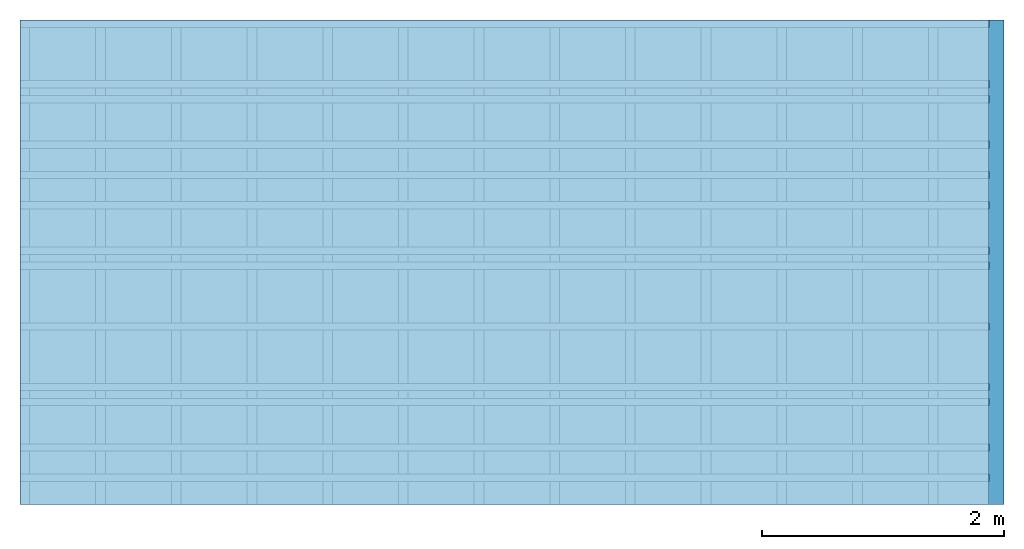
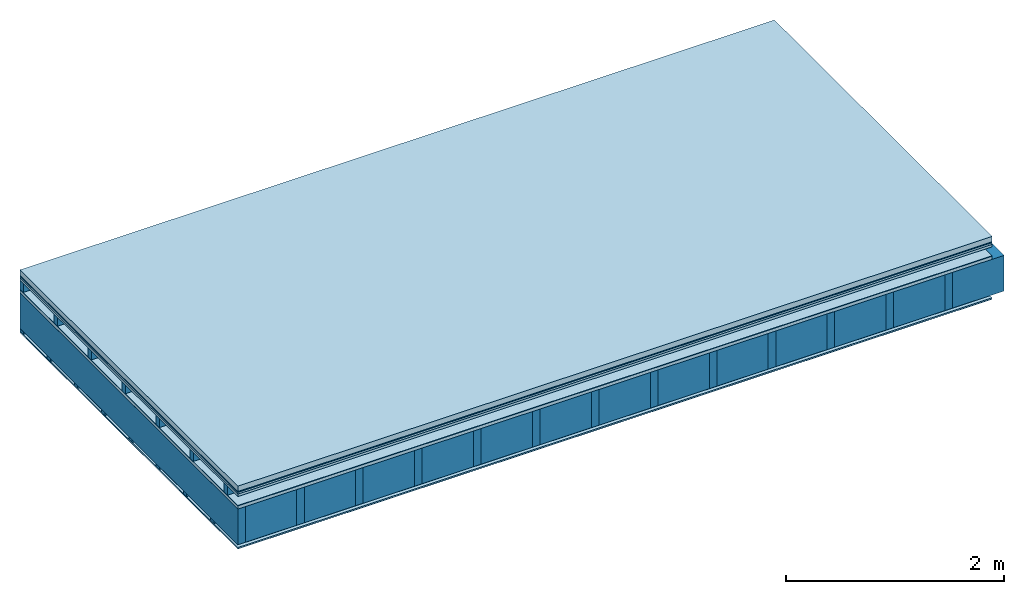
# One storey: 9 plates, 4 members, 1 element without a shape of its own.
"""IFC4 building model written with IfcOpenShell, lengths in metres."""

from ifc_helpers import new_model, si_unit, derived_unit, direction, frame, frame_2d, origin, origin_with_axes, place, context, project, spatial, rectangle, extrude, material, layer, layer_set, type_object, element, aggregate, save


model = new_model("IFC4")

# Units and contexts
plan_context = context("Plan", 3, precision=1e-05, world=origin(), true_north=direction((0.0, 1.0)))
model_context = context("Model", 3, precision=1e-05, world=origin(), true_north=direction((0.0, 1.0)))
ifc_project = project(units=[si_unit("LENGTHUNIT", "METRE"), derived_unit("SOUNDPRESSUREUNIT", [(si_unit("PRESSUREUNIT", "PASCAL", prefix="MICRO"), 0)]), si_unit("ENERGYUNIT", "JOULE", prefix="MEGA"), si_unit("MASSUNIT", "GRAM", prefix="KILO"), derived_unit("THERMALTRANSMITTANCEUNIT", [(si_unit("POWERUNIT", "WATT"), 1), (si_unit("AREAUNIT", "SQUARE_METRE"), -1), (si_unit("THERMODYNAMICTEMPERATUREUNIT", "KELVIN"), -1)]), derived_unit("AREADENSITYUNIT", [(si_unit("MASSUNIT", "GRAM", prefix="KILO"), 1), (si_unit("AREAUNIT", "SQUARE_METRE"), -1)]), derived_unit("USERDEFINED", [(si_unit("ENERGYUNIT", "JOULE", prefix="MEGA"), 1), (si_unit("AREAUNIT", "SQUARE_METRE"), -1)])], contexts=[plan_context, model_context])

# Site, building, storey
site = spatial("IfcSite", under=ifc_project)
building_placement = place(None, origin())
building = spatial("IfcBuilding", under=site, at=building_placement)
storey_placement = place(building_placement, origin())
storey = spatial("IfcBuildingStorey", under=building, at=storey_placement)

# Slab, members, plates
ifc_material_1 = material(Name="clay", Category="02.004")
ifc_layer_1 = layer(ifc_material_1, 0.06, Name="Use and protection layer 2")
ifc_material_2 = material(Name="Protective layer", Category="09.007")
ifc_layer_2 = layer(ifc_material_2, 0.01, Name="Use and protection layer 1")
ifc_material_3 = material(Name="Bituminous", Category="09.003")
ifc_layer_3 = layer(ifc_material_3, 0.02, Name="Seal")
ifc_material_4 = material(Category="07.009")
ifc_layer_4 = layer(ifc_material_4, 0.027, Name="Covering 1st layer")
ifc_layer_5 = layer(None, 0.1, Name="Battens / profiles")
ifc_material_5 = material(Name="Roofing underlay", Category="09.008")
ifc_layer_6 = layer(ifc_material_5, 0.005, Name="Under the roof")
ifc_material_6 = material(Category="10.009")
ifc_layer_7 = layer(ifc_material_6, 0.035, Name="above 2nd layer")
ifc_material_7 = material(Name="no composite action")
ifc_layer_8 = layer(ifc_material_7, 0.0, Name="Bond")
ifc_layer_9 = layer(None, 0.4, Name="Support")
ifc_material_8 = material(Name="of the art")
ifc_layer_10 = layer(ifc_material_8, 0.0, Name="Bond")
ifc_material_9 = material(Name="Vapor barrier polyethylene (PE)", Category="09.002")
ifc_layer_11 = layer(ifc_material_9, 0.001, Name="Vapor barrier")
ifc_layer_12 = layer(None, 0.03, Name="Battens / profiles")
ifc_material_10 = material(Name="DFH2IR Knauf Diamant hard- plasterboard", Category="03.007")
ifc_layer_13 = layer(ifc_material_10, 0.015, Name="Covering below 1st layer")
ifc_material_11 = material(Category="04.001")
ifc_layer_14 = layer(ifc_material_11, 0.003, Name="Surface below")
ifc_layer_set = layer_set([ifc_layer_1, ifc_layer_2, ifc_layer_3, ifc_layer_4, ifc_layer_5, ifc_layer_6, ifc_layer_7, ifc_layer_8, ifc_layer_9, ifc_layer_10, ifc_layer_11, ifc_layer_12, ifc_layer_13, ifc_layer_14])
slab_type = type_object("IfcSlabType", Name="F0120", PredefinedType="NOTDEFINED", material=ifc_layer_set)
slab_placement = place(None, frame((0.0, 0.0, 0.0), z_axis=(0.0, 0.0, -1.0), x_axis=(1.0, 0.0, 0.0)))
slab = element("IfcSlab", 1, at=slab_placement, inside=storey, type_object=slab_type, material=ifc_layer_set, Name="Slab #1")
ifc_material_12 = material()
member_1_placement = place(slab_placement, origin())
member_1 = element("IfcMember", 2, at=member_1_placement, material=ifc_material_12, Name="Battens / profiles", context=plan_context, shape_type="SweptSolid", body=[
    extrude(rectangle(XDim=0.06, YDim=0.1, at=frame_2d((0.03, 0.05), x_axis=(1.0, 0.0))), frame((0.0, 0.0, 0.117), z_axis=(1.0, 0.0, 0.0), x_axis=(0.0, 1.0, 0.0)), (0.0, 0.0, 1.0), 8.0),
    extrude(rectangle(XDim=0.06, YDim=0.1, at=frame_2d((0.03, 0.05), x_axis=(1.0, 0.0))), frame((0.0, 0.625, 0.117), z_axis=(1.0, 0.0, 0.0), x_axis=(0.0, 1.0, 0.0)), (0.0, 0.0, 1.0), 8.0),
    extrude(rectangle(XDim=0.06, YDim=0.1, at=frame_2d((0.03, 0.05), x_axis=(1.0, 0.0))), frame((0.0, 1.25, 0.117), z_axis=(1.0, 0.0, 0.0), x_axis=(0.0, 1.0, 0.0)), (0.0, 0.0, 1.0), 8.0),
    extrude(rectangle(XDim=0.06, YDim=0.1, at=frame_2d((0.03, 0.05), x_axis=(1.0, 0.0))), frame((0.0, 1.875, 0.117), z_axis=(1.0, 0.0, 0.0), x_axis=(0.0, 1.0, 0.0)), (0.0, 0.0, 1.0), 8.0),
    extrude(rectangle(XDim=0.06, YDim=0.1, at=frame_2d((0.03, 0.05), x_axis=(1.0, 0.0))), frame((0.0, 2.5, 0.117), z_axis=(1.0, 0.0, 0.0), x_axis=(0.0, 1.0, 0.0)), (0.0, 0.0, 1.0), 8.0),
    extrude(rectangle(XDim=0.06, YDim=0.1, at=frame_2d((0.03, 0.05), x_axis=(1.0, 0.0))), frame((0.0, 3.125, 0.117), z_axis=(1.0, 0.0, 0.0), x_axis=(0.0, 1.0, 0.0)), (0.0, 0.0, 1.0), 8.0),
    extrude(rectangle(XDim=0.06, YDim=0.1, at=frame_2d((0.03, 0.05), x_axis=(1.0, 0.0))), frame((0.0, 3.75, 0.117), z_axis=(1.0, 0.0, 0.0), x_axis=(0.0, 1.0, 0.0)), (0.0, 0.0, 1.0), 8.0),
])
ifc_material_13 = material()
member_2_placement = place(slab_placement, origin())
member_2 = element("IfcMember", 3, at=member_2_placement, material=ifc_material_13, Name="Support", context=plan_context, shape_type="SweptSolid", body=[
    extrude(rectangle(XDim=0.08, YDim=0.4, at=frame_2d((0.04, 0.2), x_axis=(1.0, 0.0))), frame((0.0, 4.0, 0.257), z_axis=(0.0, -1.0, 0.0), x_axis=(1.0, 0.0, 0.0)), (0.0, 0.0, 1.0), 4.0),
    extrude(rectangle(XDim=0.08, YDim=0.4, at=frame_2d((0.04, 0.2), x_axis=(1.0, 0.0))), frame((0.625, 4.0, 0.257), z_axis=(0.0, -1.0, 0.0), x_axis=(1.0, 0.0, 0.0)), (0.0, 0.0, 1.0), 4.0),
    extrude(rectangle(XDim=0.08, YDim=0.4, at=frame_2d((0.04, 0.2), x_axis=(1.0, 0.0))), frame((1.25, 4.0, 0.257), z_axis=(0.0, -1.0, 0.0), x_axis=(1.0, 0.0, 0.0)), (0.0, 0.0, 1.0), 4.0),
    extrude(rectangle(XDim=0.08, YDim=0.4, at=frame_2d((0.04, 0.2), x_axis=(1.0, 0.0))), frame((1.875, 4.0, 0.257), z_axis=(0.0, -1.0, 0.0), x_axis=(1.0, 0.0, 0.0)), (0.0, 0.0, 1.0), 4.0),
    extrude(rectangle(XDim=0.08, YDim=0.4, at=frame_2d((0.04, 0.2), x_axis=(1.0, 0.0))), frame((2.5, 4.0, 0.257), z_axis=(0.0, -1.0, 0.0), x_axis=(1.0, 0.0, 0.0)), (0.0, 0.0, 1.0), 4.0),
    extrude(rectangle(XDim=0.08, YDim=0.4, at=frame_2d((0.04, 0.2), x_axis=(1.0, 0.0))), frame((3.125, 4.0, 0.257), z_axis=(0.0, -1.0, 0.0), x_axis=(1.0, 0.0, 0.0)), (0.0, 0.0, 1.0), 4.0),
    extrude(rectangle(XDim=0.08, YDim=0.4, at=frame_2d((0.04, 0.2), x_axis=(1.0, 0.0))), frame((3.75, 4.0, 0.257), z_axis=(0.0, -1.0, 0.0), x_axis=(1.0, 0.0, 0.0)), (0.0, 0.0, 1.0), 4.0),
    extrude(rectangle(XDim=0.08, YDim=0.4, at=frame_2d((0.04, 0.2), x_axis=(1.0, 0.0))), frame((4.375, 4.0, 0.257), z_axis=(0.0, -1.0, 0.0), x_axis=(1.0, 0.0, 0.0)), (0.0, 0.0, 1.0), 4.0),
    extrude(rectangle(XDim=0.08, YDim=0.4, at=frame_2d((0.04, 0.2), x_axis=(1.0, 0.0))), frame((5.0, 4.0, 0.257), z_axis=(0.0, -1.0, 0.0), x_axis=(1.0, 0.0, 0.0)), (0.0, 0.0, 1.0), 4.0),
    extrude(rectangle(XDim=0.08, YDim=0.4, at=frame_2d((0.04, 0.2), x_axis=(1.0, 0.0))), frame((5.625, 4.0, 0.257), z_axis=(0.0, -1.0, 0.0), x_axis=(1.0, 0.0, 0.0)), (0.0, 0.0, 1.0), 4.0),
    extrude(rectangle(XDim=0.08, YDim=0.4, at=frame_2d((0.04, 0.2), x_axis=(1.0, 0.0))), frame((6.25, 4.0, 0.257), z_axis=(0.0, -1.0, 0.0), x_axis=(1.0, 0.0, 0.0)), (0.0, 0.0, 1.0), 4.0),
    extrude(rectangle(XDim=0.08, YDim=0.4, at=frame_2d((0.04, 0.2), x_axis=(1.0, 0.0))), frame((6.875, 4.0, 0.257), z_axis=(0.0, -1.0, 0.0), x_axis=(1.0, 0.0, 0.0)), (0.0, 0.0, 1.0), 4.0),
    extrude(rectangle(XDim=0.08, YDim=0.4, at=frame_2d((0.04, 0.2), x_axis=(1.0, 0.0))), frame((7.5, 4.0, 0.257), z_axis=(0.0, -1.0, 0.0), x_axis=(1.0, 0.0, 0.0)), (0.0, 0.0, 1.0), 4.0),
])
ifc_material_14 = material()
member_3_placement = place(slab_placement, origin())
member_3 = element("IfcMember", 4, at=member_3_placement, material=ifc_material_14, Name="Cavity", context=plan_context, shape_type="SweptSolid", body=[
    extrude(rectangle(XDim=0.545, YDim=0.4, at=frame_2d((0.2725, 0.2), x_axis=(1.0, 0.0))), frame((0.08, 4.0, 0.257), z_axis=(0.0, -1.0, 0.0), x_axis=(1.0, 0.0, 0.0)), (0.0, 0.0, 1.0), 4.0),
    extrude(rectangle(XDim=0.545, YDim=0.4, at=frame_2d((0.2725, 0.2), x_axis=(1.0, 0.0))), frame((0.705, 4.0, 0.257), z_axis=(0.0, -1.0, 0.0), x_axis=(1.0, 0.0, 0.0)), (0.0, 0.0, 1.0), 4.0),
    extrude(rectangle(XDim=0.545, YDim=0.4, at=frame_2d((0.2725, 0.2), x_axis=(1.0, 0.0))), frame((1.33, 4.0, 0.257), z_axis=(0.0, -1.0, 0.0), x_axis=(1.0, 0.0, 0.0)), (0.0, 0.0, 1.0), 4.0),
    extrude(rectangle(XDim=0.545, YDim=0.4, at=frame_2d((0.2725, 0.2), x_axis=(1.0, 0.0))), frame((1.955, 4.0, 0.257), z_axis=(0.0, -1.0, 0.0), x_axis=(1.0, 0.0, 0.0)), (0.0, 0.0, 1.0), 4.0),
    extrude(rectangle(XDim=0.545, YDim=0.4, at=frame_2d((0.2725, 0.2), x_axis=(1.0, 0.0))), frame((2.58, 4.0, 0.257), z_axis=(0.0, -1.0, 0.0), x_axis=(1.0, 0.0, 0.0)), (0.0, 0.0, 1.0), 4.0),
    extrude(rectangle(XDim=0.545, YDim=0.4, at=frame_2d((0.2725, 0.2), x_axis=(1.0, 0.0))), frame((3.205, 4.0, 0.257), z_axis=(0.0, -1.0, 0.0), x_axis=(1.0, 0.0, 0.0)), (0.0, 0.0, 1.0), 4.0),
    extrude(rectangle(XDim=0.545, YDim=0.4, at=frame_2d((0.2725, 0.2), x_axis=(1.0, 0.0))), frame((3.83, 4.0, 0.257), z_axis=(0.0, -1.0, 0.0), x_axis=(1.0, 0.0, 0.0)), (0.0, 0.0, 1.0), 4.0),
    extrude(rectangle(XDim=0.545, YDim=0.4, at=frame_2d((0.2725, 0.2), x_axis=(1.0, 0.0))), frame((4.455, 4.0, 0.257), z_axis=(0.0, -1.0, 0.0), x_axis=(1.0, 0.0, 0.0)), (0.0, 0.0, 1.0), 4.0),
    extrude(rectangle(XDim=0.545, YDim=0.4, at=frame_2d((0.2725, 0.2), x_axis=(1.0, 0.0))), frame((5.08, 4.0, 0.257), z_axis=(0.0, -1.0, 0.0), x_axis=(1.0, 0.0, 0.0)), (0.0, 0.0, 1.0), 4.0),
    extrude(rectangle(XDim=0.545, YDim=0.4, at=frame_2d((0.2725, 0.2), x_axis=(1.0, 0.0))), frame((5.705, 4.0, 0.257), z_axis=(0.0, -1.0, 0.0), x_axis=(1.0, 0.0, 0.0)), (0.0, 0.0, 1.0), 4.0),
    extrude(rectangle(XDim=0.545, YDim=0.4, at=frame_2d((0.2725, 0.2), x_axis=(1.0, 0.0))), frame((6.33, 4.0, 0.257), z_axis=(0.0, -1.0, 0.0), x_axis=(1.0, 0.0, 0.0)), (0.0, 0.0, 1.0), 4.0),
    extrude(rectangle(XDim=0.545, YDim=0.4, at=frame_2d((0.2725, 0.2), x_axis=(1.0, 0.0))), frame((6.955, 4.0, 0.257), z_axis=(0.0, -1.0, 0.0), x_axis=(1.0, 0.0, 0.0)), (0.0, 0.0, 1.0), 4.0),
    extrude(rectangle(XDim=0.545, YDim=0.4, at=frame_2d((0.2725, 0.2), x_axis=(1.0, 0.0))), frame((7.58, 4.0, 0.257), z_axis=(0.0, -1.0, 0.0), x_axis=(1.0, 0.0, 0.0)), (0.0, 0.0, 1.0), 4.0),
])
member_4_placement = place(slab_placement, origin())
member_4 = element("IfcMember", 5, at=member_4_placement, material=ifc_material_12, Name="Battens / profiles", context=plan_context, shape_type="SweptSolid", body=[
    extrude(rectangle(XDim=0.06, YDim=0.03, at=frame_2d((0.03, 0.015), x_axis=(1.0, 0.0))), frame((0.0, 0.0, 0.658), z_axis=(1.0, 0.0, 0.0), x_axis=(0.0, 1.0, 0.0)), (0.0, 0.0, 1.0), 8.0),
    extrude(rectangle(XDim=0.06, YDim=0.03, at=frame_2d((0.03, 0.015), x_axis=(1.0, 0.0))), frame((0.0, 0.5, 0.658), z_axis=(1.0, 0.0, 0.0), x_axis=(0.0, 1.0, 0.0)), (0.0, 0.0, 1.0), 8.0),
    extrude(rectangle(XDim=0.06, YDim=0.03, at=frame_2d((0.03, 0.015), x_axis=(1.0, 0.0))), frame((0.0, 1.0, 0.658), z_axis=(1.0, 0.0, 0.0), x_axis=(0.0, 1.0, 0.0)), (0.0, 0.0, 1.0), 8.0),
    extrude(rectangle(XDim=0.06, YDim=0.03, at=frame_2d((0.03, 0.015), x_axis=(1.0, 0.0))), frame((0.0, 1.5, 0.658), z_axis=(1.0, 0.0, 0.0), x_axis=(0.0, 1.0, 0.0)), (0.0, 0.0, 1.0), 8.0),
    extrude(rectangle(XDim=0.06, YDim=0.03, at=frame_2d((0.03, 0.015), x_axis=(1.0, 0.0))), frame((0.0, 2.0, 0.658), z_axis=(1.0, 0.0, 0.0), x_axis=(0.0, 1.0, 0.0)), (0.0, 0.0, 1.0), 8.0),
    extrude(rectangle(XDim=0.06, YDim=0.03, at=frame_2d((0.03, 0.015), x_axis=(1.0, 0.0))), frame((0.0, 2.5, 0.658), z_axis=(1.0, 0.0, 0.0), x_axis=(0.0, 1.0, 0.0)), (0.0, 0.0, 1.0), 8.0),
    extrude(rectangle(XDim=0.06, YDim=0.03, at=frame_2d((0.03, 0.015), x_axis=(1.0, 0.0))), frame((0.0, 3.0, 0.658), z_axis=(1.0, 0.0, 0.0), x_axis=(0.0, 1.0, 0.0)), (0.0, 0.0, 1.0), 8.0),
    extrude(rectangle(XDim=0.06, YDim=0.03, at=frame_2d((0.03, 0.015), x_axis=(1.0, 0.0))), frame((0.0, 3.5, 0.658), z_axis=(1.0, 0.0, 0.0), x_axis=(0.0, 1.0, 0.0)), (0.0, 0.0, 1.0), 8.0),
])
plate_1_placement = place(slab_placement, origin())
plate_1 = element("IfcPlate", 6, at=plate_1_placement, material=ifc_material_1, Name="Use and protection layer 2", context=plan_context, shape_type="SweptSolid", body=[
    extrude(rectangle(XDim=8.0, YDim=4.0, at=frame_2d((4.0, 2.0), x_axis=(1.0, 0.0))), origin_with_axes(), (0.0, 0.0, 1.0), 0.06),
])
plate_2_placement = place(slab_placement, origin())
plate_2 = element("IfcPlate", 7, at=plate_2_placement, material=ifc_material_2, Name="Use and protection layer 1", context=plan_context, shape_type="SweptSolid", body=[
    extrude(rectangle(XDim=8.0, YDim=4.0, at=frame_2d((4.0, 2.0), x_axis=(1.0, 0.0))), frame((0.0, 0.0, 0.06), z_axis=(0.0, 0.0, 1.0), x_axis=(1.0, 0.0, 0.0)), (0.0, 0.0, 1.0), 0.01),
])
plate_3_placement = place(slab_placement, origin())
plate_3 = element("IfcPlate", 8, at=plate_3_placement, material=ifc_material_3, Name="Seal", context=plan_context, shape_type="SweptSolid", body=[
    extrude(rectangle(XDim=8.0, YDim=4.0, at=frame_2d((4.0, 2.0), x_axis=(1.0, 0.0))), frame((0.0, 0.0, 0.07), z_axis=(0.0, 0.0, 1.0), x_axis=(1.0, 0.0, 0.0)), (0.0, 0.0, 1.0), 0.02),
])
plate_4_placement = place(slab_placement, origin())
plate_4 = element("IfcPlate", 9, at=plate_4_placement, material=ifc_material_4, Name="Covering 1st layer", context=plan_context, shape_type="SweptSolid", body=[
    extrude(rectangle(XDim=8.0, YDim=4.0, at=frame_2d((4.0, 2.0), x_axis=(1.0, 0.0))), frame((0.0, 0.0, 0.09), z_axis=(0.0, 0.0, 1.0), x_axis=(1.0, 0.0, 0.0)), (0.0, 0.0, 1.0), 0.027),
])
plate_5_placement = place(slab_placement, origin())
plate_5 = element("IfcPlate", 10, at=plate_5_placement, material=ifc_material_5, Name="Under the roof", context=plan_context, shape_type="SweptSolid", body=[
    extrude(rectangle(XDim=8.0, YDim=4.0, at=frame_2d((4.0, 2.0), x_axis=(1.0, 0.0))), frame((0.0, 0.0, 0.217), z_axis=(0.0, 0.0, 1.0), x_axis=(1.0, 0.0, 0.0)), (0.0, 0.0, 1.0), 0.005),
])
plate_6_placement = place(slab_placement, origin())
plate_6 = element("IfcPlate", 11, at=plate_6_placement, material=ifc_material_6, Name="above 2nd layer", context=plan_context, shape_type="SweptSolid", body=[
    extrude(rectangle(XDim=8.0, YDim=4.0, at=frame_2d((4.0, 2.0), x_axis=(1.0, 0.0))), frame((0.0, 0.0, 0.222), z_axis=(0.0, 0.0, 1.0), x_axis=(1.0, 0.0, 0.0)), (0.0, 0.0, 1.0), 0.035),
])
plate_7_placement = place(slab_placement, origin())
plate_7 = element("IfcPlate", 12, at=plate_7_placement, material=ifc_material_9, Name="Vapor barrier", context=plan_context, shape_type="SweptSolid", body=[
    extrude(rectangle(XDim=8.0, YDim=4.0, at=frame_2d((4.0, 2.0), x_axis=(1.0, 0.0))), frame((0.0, 0.0, 0.657), z_axis=(0.0, 0.0, 1.0), x_axis=(1.0, 0.0, 0.0)), (0.0, 0.0, 1.0), 0.001),
])
plate_8_placement = place(slab_placement, origin())
plate_8 = element("IfcPlate", 13, at=plate_8_placement, material=ifc_material_10, Name="Covering below 1st layer", context=plan_context, shape_type="SweptSolid", body=[
    extrude(rectangle(XDim=8.0, YDim=4.0, at=frame_2d((4.0, 2.0), x_axis=(1.0, 0.0))), frame((0.0, 0.0, 0.688), z_axis=(0.0, 0.0, 1.0), x_axis=(1.0, 0.0, 0.0)), (0.0, 0.0, 1.0), 0.015),
])
plate_9_placement = place(slab_placement, origin())
plate_9 = element("IfcPlate", 14, at=plate_9_placement, material=ifc_material_11, Name="Surface below", context=plan_context, shape_type="SweptSolid", body=[
    extrude(rectangle(XDim=8.0, YDim=4.0, at=frame_2d((4.0, 2.0), x_axis=(1.0, 0.0))), frame((0.0, 0.0, 0.703), z_axis=(0.0, 0.0, 1.0), x_axis=(1.0, 0.0, 0.0)), (0.0, 0.0, 1.0), 0.003),
])
aggregate(slab, [plate_1, plate_2, plate_3, plate_4, member_1, plate_5, plate_6, member_2, member_3, plate_7, member_4, plate_8, plate_9])

save(model, "model.ifc")
